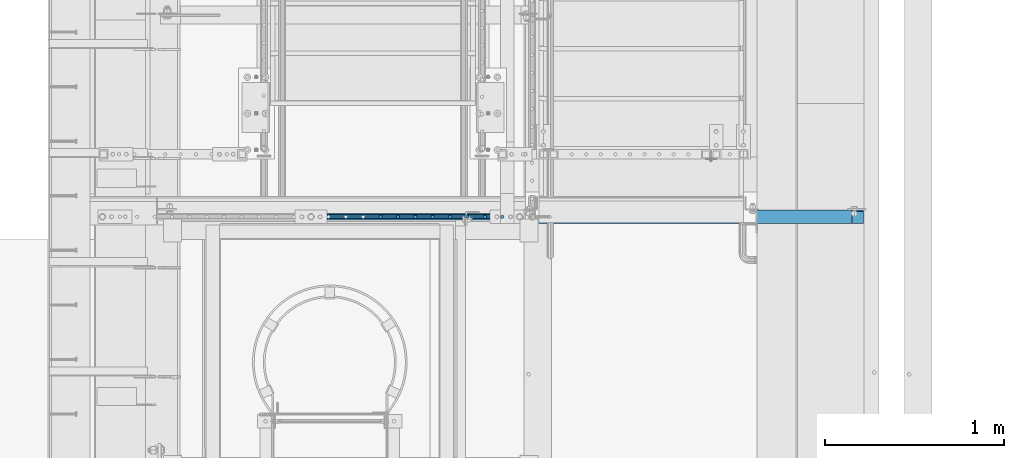
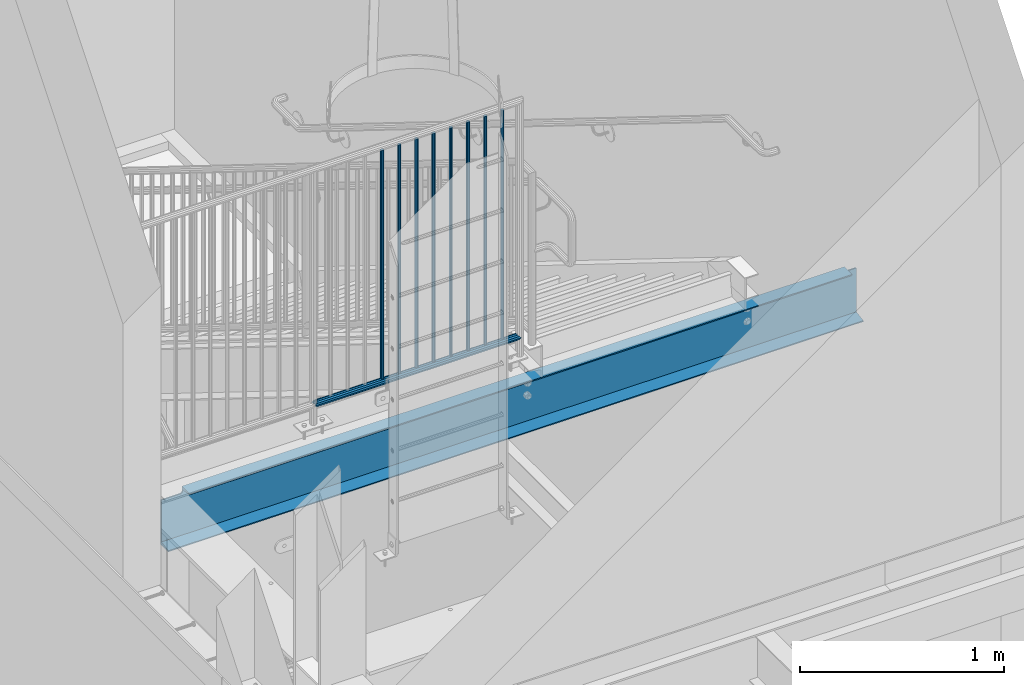
# One storey, part 1085 of 1763: 10 beams, 2 elements without a shape of their own.
"""IFC2X3 building model written with IfcOpenShell, lengths in millimetres."""

import ifcopenshell
import ifcopenshell.guid

model = None  # the IFC model being written
_history = None  # IfcOwnerHistory: only IFC2X3 demands one
_inside = {}  # id of a spatial element -> (the spatial element, [elements in it])
_under = {}  # id of a project, library or spatial element -> (it, [spatial elements below it])
_declared = {}  # id of a project -> (the project, [libraries it declares])
_typed = {}  # id of a type object -> (the type object, [elements of that type])
_made_of = {}  # id of a material, layer set ... -> (it, [elements and type objects made of it])


def new_model(schema):
    """Start an empty IFC model of exactly this schema.

    Asked for "IFC4X3", IfcOpenShell would pick the latest addendum, in which some entities
    have other attributes; the version numbers below select the first issue.
    IFC2X3 requires an IfcOwnerHistory on every rooted entity: one is made here for all.
    """
    global model, _history
    if schema == "IFC4X3":
        model = ifcopenshell.file(schema_version=(4, 3, 0, 0))
    else:
        model = ifcopenshell.file(schema=schema)
    _inside.clear()
    _under.clear()
    _declared.clear()
    _typed.clear()
    _made_of.clear()
    _history = None
    if model.schema == "IFC2X3":
        org = make("IfcOrganization", Name="unknown")
        user = make(
            "IfcPersonAndOrganization",
            ThePerson=make("IfcPerson", FamilyName="unknown"),
            TheOrganization=org,
        )
        app = make(
            "IfcApplication",
            ApplicationDeveloper=org,
            Version="unknown",
            ApplicationFullName="unknown",
            ApplicationIdentifier="unknown",
        )
        _history = make(
            "IfcOwnerHistory",
            OwningUser=user,
            OwningApplication=app,
            ChangeAction="ADDED",
            CreationDate=0,
        )
    return model


def make(cls, **values):
    """One entity of the class cls with the attributes given. An attribute that is None is left unset."""
    return model.create_entity(
        cls, **{name: value for name, value in values.items() if value is not None}
    )


def rooted(cls, **values):
    """An entity with a GlobalId (a new one), such as an element, a storey or a relation."""
    return make(cls, GlobalId=ifcopenshell.guid.new(), OwnerHistory=_history, **values)


def si_unit(unit_type, name, prefix=None):
    """IfcSIUnit, for example si_unit("LENGTHUNIT", "METRE", prefix="MILLI")."""
    return make("IfcSIUnit", UnitType=unit_type, Prefix=prefix, Name=name)


def assignment(units):
    """IfcUnitAssignment: the units of a project."""
    return None if units is None else make("IfcUnitAssignment", Units=units)


def point(xyz):
    """IfcCartesianPoint."""
    return None if xyz is None else make("IfcCartesianPoint", Coordinates=xyz)


def direction(xyz):
    """IfcDirection."""
    return None if xyz is None else make("IfcDirection", DirectionRatios=xyz)


def frame(location, z_axis=None, x_axis=None):
    """IfcAxis2Placement3D, a coordinate frame: its origin and axes. An axis left out is left unset."""
    return make(
        "IfcAxis2Placement3D",
        Location=point(location),
        Axis=direction(z_axis),
        RefDirection=direction(x_axis),
    )


def origin_with_axes():
    """The frame at (0, 0, 0) with the z axis (0, 0, 1) and the x axis (1, 0, 0) written out."""
    return frame((0.0, 0.0, 0.0), z_axis=(0.0, 0.0, 1.0), x_axis=(1.0, 0.0, 0.0))


def place(relative_to, where):
    """IfcLocalPlacement: puts the frame where relative to a parent placement (None: the world)."""
    return make(
        "IfcLocalPlacement", PlacementRelTo=relative_to, RelativePlacement=where
    )


def context(
    kind, dimensions, precision=None, world=None, true_north=None, identifier=None
):
    """IfcGeometricRepresentationContext, for example the 3D "Model" context."""
    return make(
        "IfcGeometricRepresentationContext",
        ContextIdentifier=identifier,
        ContextType=kind,
        CoordinateSpaceDimension=dimensions,
        Precision=precision,
        WorldCoordinateSystem=world,
        TrueNorth=true_north,
    )


def subcontext(parent, identifier, kind, view, scale=None):
    """IfcGeometricRepresentationSubContext, for example "Body" below "Model"."""
    return make(
        "IfcGeometricRepresentationSubContext",
        ContextIdentifier=identifier,
        ContextType=kind,
        ParentContext=parent,
        TargetScale=scale,
        TargetView=view,
    )


def project(units=None, contexts=None):
    """IfcProject with its units and contexts."""
    return rooted(
        "IfcProject",
        Name="project",
        RepresentationContexts=contexts,
        UnitsInContext=assignment(units),
    )


def spatial(cls, under=None, at=None, **own):
    """A site, building, storey or space (cls), placed at a placement, below another one or the project."""
    s = rooted(cls, ObjectPlacement=at, **own)
    if under is not None:
        _under.setdefault(under.id(), (under, []))[1].append(s)
    return s


def faces_of(points, faces, orient=None, outer=None):
    """IfcFace entities. A face is a list of loops; a loop is a list of indices into points, from 0.

    orient and outer hold one flag for each loop. By default every Orientation is true, the
    first loop of a face is its IfcFaceOuterBound and the others are IfcFaceBound.
    """
    made = []
    for i, loops in enumerate(faces):
        bounds = []
        for j, loop in enumerate(loops):
            is_outer = j == 0 if outer is None else outer[i][j]
            bounds.append(
                make(
                    "IfcFaceOuterBound" if is_outer else "IfcFaceBound",
                    Bound=make("IfcPolyLoop", Polygon=[points[k] for k in loop]),
                    Orientation=True if orient is None else orient[i][j],
                )
            )
        made.append(make("IfcFace", Bounds=bounds))
    return made


def faceted_brep(points, faces, orient=None, outer=None, voids=None):
    """IfcFacetedBrep: a solid bounded by flat faces; with voids (closed shells), ...WithVoids."""
    shared = [point(p) for p in points]
    hull = make("IfcClosedShell", CfsFaces=faces_of(shared, faces, orient, outer))
    if voids is None:
        return make("IfcFacetedBrep", Outer=hull)
    return make(
        "IfcFacetedBrepWithVoids",
        Outer=hull,
        Voids=[
            make(cls, CfsFaces=faces_of(shared, fs, o, b)) for cls, fs, o, b in voids
        ],
    )


def shape(context_of_items, identifier, shape_type, items):
    """IfcShapeRepresentation: the items that make up one representation, for example the "Body"."""
    return make(
        "IfcShapeRepresentation",
        ContextOfItems=context_of_items,
        RepresentationIdentifier=identifier,
        RepresentationType=shape_type,
        Items=items,
    )


def material(Name=None, Category=None):
    """IfcMaterial."""
    return make("IfcMaterial", Name=Name, Category=Category)


def made_of(thing, what):
    """Note that an element or type object is made of a material, layer set ...; save() writes the relation."""
    if what is not None:
        _made_of.setdefault(what.id(), (what, []))[1].append(thing)
    return thing


def type_object(cls, material=None, **own):
    """A type object (cls), such as IfcWallType, which elements share."""
    return made_of(rooted(cls, **own), material)


def element(
    cls,
    number,
    at=None,
    inside=None,
    cuts=None,
    type_object=None,
    material=None,
    context=None,
    identifier="Body",
    shape_type=None,
    held_by="IfcProductDefinitionShape",
    body=None,
    shapes=None,
    **own,
):
    """One element of the class cls, such as IfcWall. Its Tag is "e" and its number.

    at: its placement. inside: the storey or other place that contains it. cuts: it is an
    opening in that element (IfcRelVoidsElement). A single representation is given by context,
    identifier, shape_type and body (its items); several are given by shapes. held_by: the class
    of the entity that holds the representations. save() writes the other relations.
    """
    e = rooted(cls, Tag="e%d" % number, ObjectPlacement=at, **own)
    if body is not None:
        shapes = [shape(context, identifier, shape_type, body)]
    if shapes is not None:
        e.Representation = make(held_by, Representations=shapes)
    if inside is not None:
        _inside.setdefault(inside.id(), (inside, []))[1].append(e)
    if cuts is not None:
        rooted(
            "IfcRelVoidsElement", RelatingBuildingElement=cuts, RelatedOpeningElement=e
        )
    if type_object is not None:
        _typed.setdefault(type_object.id(), (type_object, []))[1].append(e)
    return made_of(e, material)


def aggregate(whole, parts):
    """IfcRelAggregates: a whole, such as a stair, and the parts it consists of."""
    return rooted("IfcRelAggregates", RelatingObject=whole, RelatedObjects=parts)


def save(model, path):
    """Write the relations noted so far, then the file.

    IfcRelAggregates (storeys below a building ...), IfcRelContainedInSpatialStructure (elements
    in a storey), IfcRelDefinesByType, IfcRelAssociatesMaterial and IfcRelDeclares: one each for
    every whole, place, type object, material and project.
    """
    for whole, parts in _under.values():
        aggregate(whole, parts)
    for where, things in _inside.values():
        rooted(
            "IfcRelContainedInSpatialStructure",
            RelatedElements=things,
            RelatingStructure=where,
        )
    for kind, things in _typed.values():
        rooted("IfcRelDefinesByType", RelatedObjects=things, RelatingType=kind)
    for what, things in _made_of.values():
        rooted("IfcRelAssociatesMaterial", RelatedObjects=things, RelatingMaterial=what)
    for by, libraries in _declared.values():
        rooted("IfcRelDeclares", RelatingContext=by, RelatedDefinitions=libraries)
    model.write(path)


model = new_model("IFC2X3")

# Units and contexts
model_context = context("Model", 3, precision=1e-05, world=origin_with_axes())
body_context = subcontext(model_context, "Body", "Model", "MODEL_VIEW")
ifc_project = project(units=[si_unit("LENGTHUNIT", "METRE", prefix="MILLI"), si_unit("AREAUNIT", "SQUARE_METRE"), si_unit("VOLUMEUNIT", "CUBIC_METRE"), si_unit("MASSUNIT", "GRAM", prefix="KILO"), si_unit("TIMEUNIT", "SECOND"), si_unit("PLANEANGLEUNIT", "RADIAN"), si_unit("SOLIDANGLEUNIT", "STERADIAN"), si_unit("THERMODYNAMICTEMPERATUREUNIT", "DEGREE_CELSIUS"), si_unit("LUMINOUSINTENSITYUNIT", "LUMEN")], contexts=[model_context])

# Site, building, storey
site_placement = place(None, origin_with_axes())
site = spatial("IfcSite", under=ifc_project, at=site_placement, CompositionType="ELEMENT")
building_placement = place(site_placement, origin_with_axes())
building = spatial("IfcBuilding", under=site, at=building_placement, Name="Undefined", CompositionType="ELEMENT")
storey_placement = place(building_placement, origin_with_axes())
storey = spatial("IfcBuildingStorey", under=building, at=storey_placement, Name="Undefined", CompositionType="ELEMENT", Elevation=0.0)

# Assembly, beam
assembly_1_placement = place(storey_placement, origin_with_axes())
assembly_1 = element("IfcElementAssembly", 1, at=assembly_1_placement, inside=storey, Name="RAIL", AssemblyPlace="NOTDEFINED", PredefinedType="RIGID_FRAME")
ifc_material_1 = material(Name="STEEL/A513")
beam_type_1 = type_object("IfcBeamType", PredefinedType="NOTDEFINED")
beam_1_placement = place(assembly_1_placement, frame((-85349.7221005486, 31673.8000014519, 5454.64999991884), z_axis=(0.0, 0.0, 1.0), x_axis=(-1.0, 0.0, 0.0)))
beam_1 = element("IfcBeam", 2, at=beam_1_placement, type_object=beam_type_1, material=ifc_material_1, Name="RAIL", context=body_context, shape_type="Brep", body=[
    faceted_brep([(1148.75980258887, -9.52499999949214, 16.4977839420935), (1148.75980258887, -9.52500036633865, 11.4667120131071), (1148.26637405265, -7.68349999948987, 13.3082123799559), (1146.20758653089, 5.74800651520491e-10, 15.3670000000002), (1146.20758653089, 5.74800651520491e-10, 19.0500000000002), (1148.26637424916, 7.6835000005085, 13.3082123799559), (1148.75980258873, 9.52499963366063, 11.4667127468038), (1148.75980258873, 9.52500000051077, 16.4977839420935), (1165.25758657494, 19.0500000005159, 0.0), (1155.73258653076, 16.4977839426028, 9.52499999999964), (1155.73258653076, 16.4977839426028, -9.52499999999964), (1152.54301533551, 13.308212380467, 7.68350000000009), (1154.60180295554, 15.3670000005113, 0.0), (1152.54301533551, 13.308212380467, -7.68350000000009), (1148.75980258873, 9.52499963366063, -11.4667127468038), (1148.75980258873, 9.52500000051077, -16.4977839420935), (1148.26637424916, 7.6835000005085, -13.3082123799559), (1146.20758653089, 5.0931703299284e-10, -15.3670000000002), (1146.20758653089, 5.0931703299284e-10, -19.0500000000002), (1148.75980258887, -9.52500036633865, -11.4667120131071), (1148.75980258887, -9.52499999949214, -16.4977839420935), (1148.26637405265, -7.68349999948987, -13.3082123799559), (1165.25758653104, -19.050000366391, 0.0), (1155.73258653101, -16.4977839415842, -9.52499999999964), (1155.73258653101, -16.4977839415842, 9.52499999999964), (1152.54301460199, -13.3082123794447, -7.68350000000009), (1154.60180222205, -15.3669999994891, 0.0), (1152.54301460199, -13.3082123794447, 7.68350000000009), (9.52499999467545, -16.4977839420899, -9.52500000000009), (16.4977839367712, -9.52499999999418, -16.4977839420935), (0.0, 19.0500000000029, 0.0), (9.52499999467545, 16.4977839420899, -9.52500000000009), (9.52500000096188, 16.4977839420899, 9.52500000000009), (16.4977839430576, 9.52499999999418, 16.4977839420935), (19.0500000009633, 0.0, 19.0500000000002), (16.4977839367712, 9.52499999999418, -16.4977839420935), (19.0499999946769, 0.0, -19.0500000000002), (19.0499999946769, 0.0, -15.3670000000002), (16.4977839367712, -9.52500000031432, -11.4667123796353), (16.9912123747126, -7.68349999999919, -13.3082123799554), (16.9912123745453, 7.68349999999919, -13.3082123799554), (16.4977839367712, 9.52499999967404, -11.4667123802756), (12.7145715564911, 13.3082123799541, -7.68350000000009), (10.6557839364468, 15.3669999999984, 0.0), (12.7145715564911, 13.3082123799541, 7.68350000000009), (16.4977839367712, 9.52499999967404, 11.4667123802756), (16.9912123745453, 7.68349999999919, 13.3082123799554), (19.0499999946769, -3.20142135024071e-10, 15.3670000000002), (16.9912123747126, -7.68349999999919, 13.3082123799554), (16.4977839367712, -9.52500000031432, 11.4667123796353), (16.4977839430576, -9.52499999999418, 16.4977839420935), (9.52500000096188, -16.4977839420899, 9.52500000000009), (0.0, -19.0500000000029, 0.0), (12.7145715571314, -13.3082123799541, 7.68350000000009), (10.6557839370871, -15.3669999999984, 0.0), (12.7145715571314, -13.3082123799541, -7.68350000000009)], [[[0, 1, 2, 3, 4]], [[4, 3, 5, 6, 7]], [[8, 9, 10]], [[7, 6, 11, 12, 13, 14, 15, 10, 9]], [[16, 17, 18, 15, 14]], [[19, 20, 18, 17, 21]], [[22, 23, 24]], [[24, 23, 20, 19, 25, 26, 27, 1, 0]], [[28, 29, 20, 23]], [[30, 31, 32]], [[33, 34, 4, 7]], [[32, 33, 7, 9]], [[30, 32, 9, 8]], [[31, 30, 8, 10]], [[35, 31, 10, 15]], [[36, 35, 15, 18]], [[29, 36, 18, 20]], [[37, 36, 29, 38, 39]], [[40, 41, 35, 36, 37]], [[32, 31, 35, 41, 42, 43, 44, 45, 33]], [[33, 45, 46, 47, 34]], [[34, 47, 48, 49, 50]], [[34, 50, 0, 4]], [[50, 51, 24, 0]], [[51, 52, 22, 24]], [[52, 28, 23, 22]], [[51, 28, 52]], [[50, 49, 53, 54, 55, 38, 29, 28, 51]], [[55, 54, 26, 25]], [[21, 39, 38, 55, 25, 19]], [[37, 39, 21, 17]], [[40, 37, 17, 16]], [[42, 41, 40, 16, 14, 13]], [[43, 42, 13, 12]], [[44, 43, 12, 11]], [[5, 46, 45, 44, 11, 6]], [[47, 46, 5, 3]], [[48, 47, 3, 2]], [[53, 49, 48, 2, 1, 27]], [[54, 53, 27, 26]]]),
])

assembly_2_placement = place(storey_placement, origin_with_axes())
assembly_2 = element("IfcElementAssembly", 3, at=assembly_2_placement, inside=storey, Name="CHANNEL", AssemblyPlace="NOTDEFINED", PredefinedType="RIGID_FRAME")
ifc_material_2 = material(Name="STEEL/A36")
beam_type_2 = type_object("IfcBeamType", Name="C12X20.7", PredefinedType="NOTDEFINED")
beam_2_placement = place(assembly_2_placement, frame((-83413.0372736991, 31673.8000001342, 5041.90000001303), z_axis=(0.0, 0.0, -1.0), x_axis=(-1.0, 0.0, 0.0)))
beam_2 = element("IfcBeam", 4, at=beam_2_placement, type_object=beam_type_2, material=ifc_material_2, Name="CHANNEL", ObjectType="C12X20.7", context=body_context, shape_type="Brep", body=[
    faceted_brep([(3821.90624999929, 30.1624999999985, -134.6749275), (3821.90624999929, -38.0999999999985, -146.04746), (3821.90624999929, -38.0999999999985, -152.4), (3821.90624999929, 38.0999999999985, -152.4), (3821.90624999929, 38.0999999999985, -126.999999809265), (3821.90624999929, 30.1624999999985, -126.999999809265), (3822.87297992187, 38.0999999999985, -122.13992029122), (3822.87297992187, 30.1624999999985, -122.13992029122), (3825.62599382235, 38.0999999999985, -118.019743823066), (3825.62599382235, 30.1624999999985, -118.019743823066), (3829.74617029051, 38.0999999999985, -115.266729922588), (3829.74617029051, 30.1624999999985, -115.266729922588), (3834.60624980855, 38.0999999999985, -114.3), (3834.60624980855, 30.1624999999985, -114.3), (3942.55624999927, 30.1624999999985, -114.3), (3942.55624999927, 38.0999999999985, -114.3), (15.8749999992579, -38.0999999999985, 152.4), (15.8749999992579, -38.0999999999985, 146.04746), (3942.55624999927, -38.0999999999985, 146.04746), (3942.55624999927, -38.0999999999985, 152.4), (15.8749999992579, 38.0999999999985, 152.4), (3942.55624999927, 38.0999999999985, 152.4), (79.3749999992579, 1.14487193059176e-06, -139.699999809264), (79.3749999992579, 38.0999999999985, -139.699999809264), (79.3749999992579, 38.0999999999985, -152.4), (79.3749999992579, -38.0999999999985, -152.4), (79.3749999992579, -38.0999999999985, -146.04746), (78.4082700766739, 30.1624999999985, -134.6749275), (78.4082700766739, 38.0999999999985, -134.839920291219), (75.6552561761928, 30.1624999999985, -130.719743823065), (75.6552561761928, 38.0999999999985, -130.719743823065), (71.5350797080318, 30.1624999999985, -127.966729922587), (71.5350797080318, 38.0999999999985, -127.966729922587), (66.6750001899927, 30.1624999999985, -126.999999999999), (66.6750001899927, 38.0999999999985, -126.999999999999), (15.8749999992579, 30.1624999999985, -126.999999999999), (15.8749999992579, 38.0999999999985, -126.999999999999), (15.8749999992579, 30.1624999999985, 134.6749275), (3942.55624999927, 30.1624999999985, 134.6749275)], [[[0, 1, 2, 3, 4, 5]], [[5, 4, 6, 7]], [[7, 6, 8, 9]], [[9, 8, 10, 11]], [[11, 10, 12, 13]], [[14, 13, 12, 15]], [[16, 17, 18, 19]], [[20, 16, 19, 21]], [[22, 23, 24, 25, 26]], [[27, 28, 23, 22]], [[29, 30, 28, 27]], [[31, 32, 30, 29]], [[33, 34, 32, 31]], [[35, 36, 34, 33]], [[37, 17, 16, 20, 36, 35]], [[17, 37, 38, 18]], [[21, 19, 18, 38, 14, 15]], [[10, 8, 6, 4, 3, 24, 23, 28, 30, 32, 34, 36, 20, 21, 15, 12]], [[25, 24, 3, 2]], [[26, 25, 2, 1]], [[27, 22, 26, 1, 0]], [[38, 37, 35, 33, 31, 29, 27, 0, 5, 7, 9, 11, 13, 14]]]),
])
aggregate(assembly_2, [beam_2])

# Beam
beam_type_3 = type_object("IfcBeamType", PredefinedType="NOTDEFINED")
beam_3_placement = place(assembly_1_placement, frame((-86126.5604915986, 31673.8000008236, 6857.99999991884), z_axis=(0.0, -1.0, 0.0), x_axis=(0.0, 0.0, -1.0)))
beam_3 = element("IfcBeam", 5, at=beam_3_placement, type_object=beam_type_3, material=ifc_material_2, Name="PICKET", context=body_context, shape_type="Brep", body=[
    faceted_brep([(19.0499999999092, -9.52500000000146, 0.0), (19.0499999999092, -6.73519209080405, -6.73519209079677), (1384.29999999477, -6.73519209082588, -6.73519209079677), (1384.29999999477, -9.52499999999418, 3.63797880709171e-12), (19.0499999999092, 0.0, -9.52499999999418), (1384.29999999477, -4.36557456851006e-11, -9.52500000000146), (19.0499999999092, 6.73519209080405, -6.73519209079677), (1384.29999999477, 6.73519209078222, -6.73519209080769), (19.0499999999092, 9.52500000000146, 0.0), (1384.29999999477, 9.52499999999418, -3.63797880709171e-12), (19.0499999999092, 6.73519209080405, 6.73519209079677), (1384.29999999477, 6.73519209082588, 6.73519209079677), (19.0499999999092, 0.0, 9.52499999999418), (1384.29999999477, 2.91038304567337e-11, 9.52500000000146), (19.0499999999092, -6.73519209080405, 6.73519209079677), (1384.29999999477, -6.73519209078222, 6.73519209080769)], [[[0, 1, 2, 3]], [[1, 4, 5, 2]], [[4, 6, 7, 5]], [[6, 8, 9, 7]], [[8, 10, 11, 9]], [[10, 12, 13, 11]], [[12, 14, 15, 13]], [[14, 0, 3, 15]], [[5, 7, 9, 11, 13, 15, 3, 2]], [[14, 12, 10, 8, 6, 4, 1, 0]]]),
])

beam_4_placement = place(assembly_1_placement, frame((-86029.4556927173, 31673.8000008985, 6857.99999991884), z_axis=(0.0, -1.0, 0.0), x_axis=(0.0, 0.0, -1.0)))
beam_4 = element("IfcBeam", 6, at=beam_4_placement, type_object=beam_type_3, material=ifc_material_2, Name="PICKET", context=body_context, shape_type="Brep", body=[
    faceted_brep([(19.0499999999092, -9.52500000000146, 0.0), (19.0499999999092, -6.73519209080405, -6.73519209079677), (1384.29999999477, -6.73519209082588, -6.73519209079677), (1384.29999999477, -9.52499999999418, 3.63797880709171e-12), (19.0499999999092, 0.0, -9.52499999999418), (1384.29999999477, -4.36557456851006e-11, -9.52500000000146), (19.0499999999092, 6.73519209080405, -6.73519209079677), (1384.29999999477, 6.73519209078222, -6.73519209080769), (19.0499999999092, 9.52500000000146, 0.0), (1384.29999999477, 9.52499999999418, -3.63797880709171e-12), (19.0499999999092, 6.73519209080405, 6.73519209079677), (1384.29999999477, 6.73519209082588, 6.73519209079677), (19.0499999999092, 0.0, 9.52499999999418), (1384.29999999477, 2.91038304567337e-11, 9.52500000000146), (19.0499999999092, -6.73519209080405, 6.73519209079677), (1384.29999999477, -6.73519209078222, 6.73519209080769)], [[[0, 1, 2, 3]], [[1, 4, 5, 2]], [[4, 6, 7, 5]], [[6, 8, 9, 7]], [[8, 10, 11, 9]], [[10, 12, 13, 11]], [[12, 14, 15, 13]], [[14, 0, 3, 15]], [[5, 7, 9, 11, 13, 15, 3, 2]], [[14, 12, 10, 8, 6, 4, 1, 0]]]),
])

beam_5_placement = place(assembly_1_placement, frame((-85932.3508938361, 31673.8000009734, 6857.99999991884), z_axis=(0.0, -1.0, 0.0), x_axis=(0.0, 0.0, -1.0)))
beam_5 = element("IfcBeam", 7, at=beam_5_placement, type_object=beam_type_3, material=ifc_material_2, Name="PICKET", context=body_context, shape_type="Brep", body=[
    faceted_brep([(19.0499999999092, -9.52500000000146, 0.0), (19.0499999999092, -6.73519209080405, -6.73519209079677), (1384.29999999477, -6.73519209082588, -6.73519209079677), (1384.29999999477, -9.52499999999418, 3.63797880709171e-12), (19.0499999999092, 0.0, -9.52499999999418), (1384.29999999477, -4.36557456851006e-11, -9.52500000000146), (19.0499999999092, 6.73519209080405, -6.73519209079677), (1384.29999999477, 6.73519209078222, -6.73519209080769), (19.0499999999092, 9.52500000000146, 0.0), (1384.29999999477, 9.52499999999418, -3.63797880709171e-12), (19.0499999999092, 6.73519209080405, 6.73519209079677), (1384.29999999477, 6.73519209082588, 6.73519209079677), (19.0499999999092, 0.0, 9.52499999999418), (1384.29999999477, 2.91038304567337e-11, 9.52500000000146), (19.0499999999092, -6.73519209080405, 6.73519209079677), (1384.29999999477, -6.73519209078222, 6.73519209080769)], [[[0, 1, 2, 3]], [[1, 4, 5, 2]], [[4, 6, 7, 5]], [[6, 8, 9, 7]], [[8, 10, 11, 9]], [[10, 12, 13, 11]], [[12, 14, 15, 13]], [[14, 0, 3, 15]], [[5, 7, 9, 11, 13, 15, 3, 2]], [[14, 12, 10, 8, 6, 4, 1, 0]]]),
])

beam_6_placement = place(assembly_1_placement, frame((-85835.2460949548, 31673.8000010483, 6857.99999991884), z_axis=(0.0, -1.0, 0.0), x_axis=(0.0, 0.0, -1.0)))
beam_6 = element("IfcBeam", 8, at=beam_6_placement, type_object=beam_type_3, material=ifc_material_2, Name="PICKET", context=body_context, shape_type="Brep", body=[
    faceted_brep([(19.0499999999092, -9.52500000000146, 0.0), (19.0499999999092, -6.73519209080405, -6.73519209079677), (1384.29999999477, -6.73519209082588, -6.73519209079677), (1384.29999999477, -9.52499999999418, 3.63797880709171e-12), (19.0499999999092, 0.0, -9.52499999999418), (1384.29999999477, -4.36557456851006e-11, -9.52500000000146), (19.0499999999092, 6.73519209080405, -6.73519209079677), (1384.29999999477, 6.73519209078222, -6.73519209080769), (19.0499999999092, 9.52500000000146, 0.0), (1384.29999999477, 9.52499999999418, -3.63797880709171e-12), (19.0499999999092, 6.73519209080405, 6.73519209079677), (1384.29999999477, 6.73519209082588, 6.73519209079677), (19.0499999999092, 0.0, 9.52499999999418), (1384.29999999477, 2.91038304567337e-11, 9.52500000000146), (19.0499999999092, -6.73519209080405, 6.73519209079677), (1384.29999999477, -6.73519209078222, 6.73519209080769)], [[[0, 1, 2, 3]], [[1, 4, 5, 2]], [[4, 6, 7, 5]], [[6, 8, 9, 7]], [[8, 10, 11, 9]], [[10, 12, 13, 11]], [[12, 14, 15, 13]], [[14, 0, 3, 15]], [[5, 7, 9, 11, 13, 15, 3, 2]], [[14, 12, 10, 8, 6, 4, 1, 0]]]),
])

beam_7_placement = place(assembly_1_placement, frame((-85738.1412960736, 31673.8000011232, 6857.99999991884), z_axis=(0.0, -1.0, 0.0), x_axis=(0.0, 0.0, -1.0)))
beam_7 = element("IfcBeam", 9, at=beam_7_placement, type_object=beam_type_3, material=ifc_material_2, Name="PICKET", context=body_context, shape_type="Brep", body=[
    faceted_brep([(19.0499999999092, -9.52500000000146, 0.0), (19.0499999999092, -6.73519209080405, -6.73519209079677), (1384.29999999477, -6.73519209082588, -6.73519209079677), (1384.29999999477, -9.52499999999418, 3.63797880709171e-12), (19.0499999999092, 0.0, -9.52499999999418), (1384.29999999477, -4.36557456851006e-11, -9.52500000000146), (19.0499999999092, 6.73519209080405, -6.73519209079677), (1384.29999999477, 6.73519209078222, -6.73519209080769), (19.0499999999092, 9.52500000000146, 0.0), (1384.29999999477, 9.52499999999418, -3.63797880709171e-12), (19.0499999999092, 6.73519209080405, 6.73519209079677), (1384.29999999477, 6.73519209082588, 6.73519209079677), (19.0499999999092, 0.0, 9.52499999999418), (1384.29999999477, 2.91038304567337e-11, 9.52500000000146), (19.0499999999092, -6.73519209080405, 6.73519209079677), (1384.29999999477, -6.73519209078222, 6.73519209080769)], [[[0, 1, 2, 3]], [[1, 4, 5, 2]], [[4, 6, 7, 5]], [[6, 8, 9, 7]], [[8, 10, 11, 9]], [[10, 12, 13, 11]], [[12, 14, 15, 13]], [[14, 0, 3, 15]], [[5, 7, 9, 11, 13, 15, 3, 2]], [[14, 12, 10, 8, 6, 4, 1, 0]]]),
])

beam_8_placement = place(assembly_1_placement, frame((-85641.0364971923, 31673.8000011981, 6857.99999991884), z_axis=(0.0, -1.0, 0.0), x_axis=(0.0, 0.0, -1.0)))
beam_8 = element("IfcBeam", 10, at=beam_8_placement, type_object=beam_type_3, material=ifc_material_2, Name="PICKET", context=body_context, shape_type="Brep", body=[
    faceted_brep([(19.0499999999092, -9.52500000000146, 0.0), (19.0499999999092, -6.73519209080405, -6.73519209079677), (1384.29999999477, -6.73519209082588, -6.73519209079677), (1384.29999999477, -9.52499999999418, 3.63797880709171e-12), (19.0499999999092, 0.0, -9.52499999999418), (1384.29999999477, -4.36557456851006e-11, -9.52500000000146), (19.0499999999092, 6.73519209080405, -6.73519209079677), (1384.29999999477, 6.73519209078222, -6.73519209080769), (19.0499999999092, 9.52500000000146, 0.0), (1384.29999999477, 9.52499999999418, -3.63797880709171e-12), (19.0499999999092, 6.73519209080405, 6.73519209079677), (1384.29999999477, 6.73519209082588, 6.73519209079677), (19.0499999999092, 0.0, 9.52499999999418), (1384.29999999477, 2.91038304567337e-11, 9.52500000000146), (19.0499999999092, -6.73519209080405, 6.73519209079677), (1384.29999999477, -6.73519209078222, 6.73519209080769)], [[[0, 1, 2, 3]], [[1, 4, 5, 2]], [[4, 6, 7, 5]], [[6, 8, 9, 7]], [[8, 10, 11, 9]], [[10, 12, 13, 11]], [[12, 14, 15, 13]], [[14, 0, 3, 15]], [[5, 7, 9, 11, 13, 15, 3, 2]], [[14, 12, 10, 8, 6, 4, 1, 0]]]),
])

beam_9_placement = place(assembly_1_placement, frame((-85543.9316983111, 31673.800001273, 6857.99999991884), z_axis=(0.0, -1.0, 0.0), x_axis=(0.0, 0.0, -1.0)))
beam_9 = element("IfcBeam", 11, at=beam_9_placement, type_object=beam_type_3, material=ifc_material_2, Name="PICKET", context=body_context, shape_type="Brep", body=[
    faceted_brep([(19.0499999999092, -9.52500000000146, 0.0), (19.0499999999092, -6.73519209080405, -6.73519209079677), (1384.29999999477, -6.73519209082588, -6.73519209079677), (1384.29999999477, -9.52499999999418, 3.63797880709171e-12), (19.0499999999092, 0.0, -9.52499999999418), (1384.29999999477, -4.36557456851006e-11, -9.52500000000146), (19.0499999999092, 6.73519209080405, -6.73519209079677), (1384.29999999477, 6.73519209078222, -6.73519209080769), (19.0499999999092, 9.52500000000146, 0.0), (1384.29999999477, 9.52499999999418, -3.63797880709171e-12), (19.0499999999092, 6.73519209080405, 6.73519209079677), (1384.29999999477, 6.73519209082588, 6.73519209079677), (19.0499999999092, 0.0, 9.52499999999418), (1384.29999999477, 2.91038304567337e-11, 9.52500000000146), (19.0499999999092, -6.73519209080405, 6.73519209079677), (1384.29999999477, -6.73519209078222, 6.73519209080769)], [[[0, 1, 2, 3]], [[1, 4, 5, 2]], [[4, 6, 7, 5]], [[6, 8, 9, 7]], [[8, 10, 11, 9]], [[10, 12, 13, 11]], [[12, 14, 15, 13]], [[14, 0, 3, 15]], [[5, 7, 9, 11, 13, 15, 3, 2]], [[14, 12, 10, 8, 6, 4, 1, 0]]]),
])

beam_10_placement = place(assembly_1_placement, frame((-85446.8268994298, 31673.8000013479, 6857.99999991884), z_axis=(0.0, -1.0, 0.0), x_axis=(0.0, 0.0, -1.0)))
beam_10 = element("IfcBeam", 12, at=beam_10_placement, type_object=beam_type_3, material=ifc_material_2, Name="PICKET", context=body_context, shape_type="Brep", body=[
    faceted_brep([(19.0499999999092, -9.52500000000146, 0.0), (19.0499999999092, -6.73519209080405, -6.73519209079677), (1384.29999999477, -6.73519209082588, -6.73519209079677), (1384.29999999477, -9.52499999999418, 3.63797880709171e-12), (19.0499999999092, 0.0, -9.52499999999418), (1384.29999999477, -4.36557456851006e-11, -9.52500000000146), (19.0499999999092, 6.73519209080405, -6.73519209079677), (1384.29999999477, 6.73519209078222, -6.73519209080769), (19.0499999999092, 9.52500000000146, 0.0), (1384.29999999477, 9.52499999999418, -3.63797880709171e-12), (19.0499999999092, 6.73519209080405, 6.73519209079677), (1384.29999999477, 6.73519209082588, 6.73519209079677), (19.0499999999092, 0.0, 9.52499999999418), (1384.29999999477, 2.91038304567337e-11, 9.52500000000146), (19.0499999999092, -6.73519209080405, 6.73519209079677), (1384.29999999477, -6.73519209078222, 6.73519209080769)], [[[0, 1, 2, 3]], [[1, 4, 5, 2]], [[4, 6, 7, 5]], [[6, 8, 9, 7]], [[8, 10, 11, 9]], [[10, 12, 13, 11]], [[12, 14, 15, 13]], [[14, 0, 3, 15]], [[5, 7, 9, 11, 13, 15, 3, 2]], [[14, 12, 10, 8, 6, 4, 1, 0]]]),
])

aggregate(assembly_1, [beam_3, beam_4, beam_5, beam_6, beam_7, beam_8, beam_9, beam_10, beam_1])

save(model, "model.ifc")
